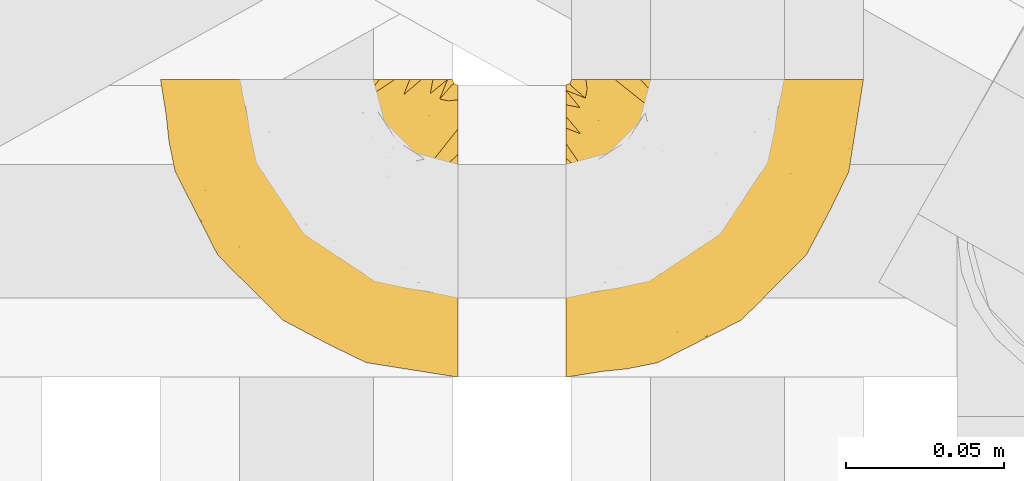
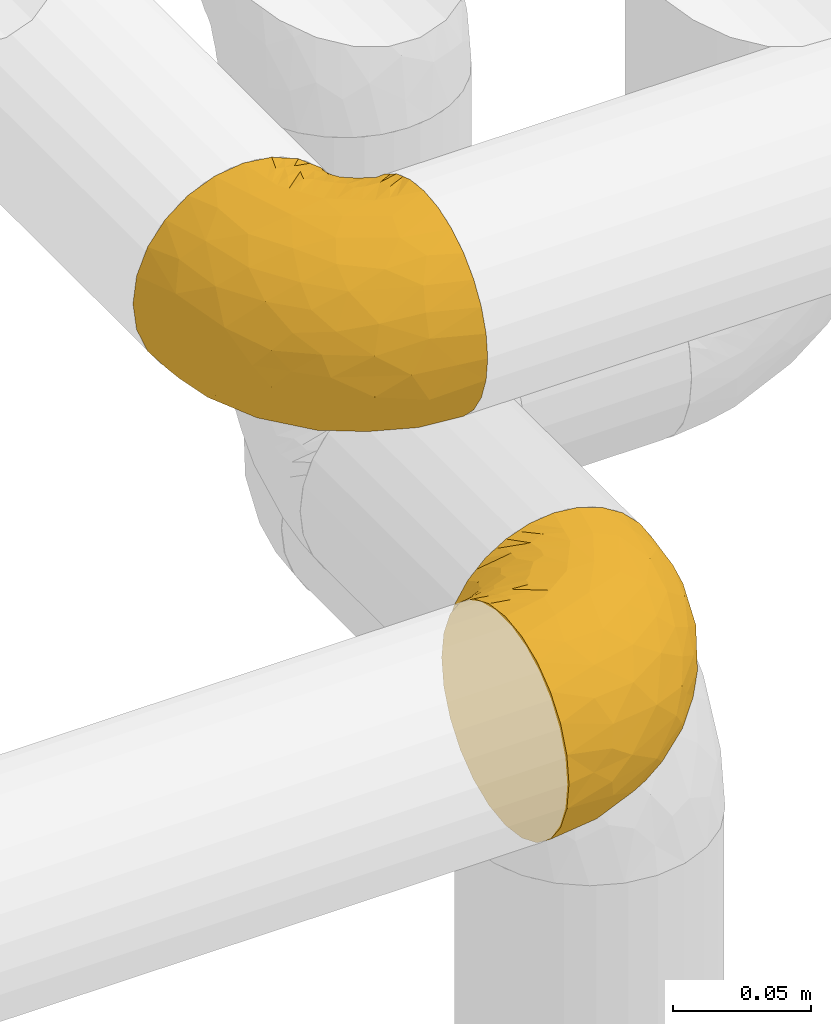
# One storey, part 173 of 827: 2 coverings.
"""IFC2X3 building model written with IfcOpenShell, lengths in millimetres."""

from ifc_helpers import new_model, entity, si_unit, converted_unit, derived_unit, direction, frame, origin, place, context, subcontext, project, spatial, faceted_brep, element, save


model = new_model("IFC2X3")

# Units and contexts
model_context = context("Model", 3, precision=0.01, world=origin(), true_north=direction((6.12303176911189e-17, 1.0)))
body_context = subcontext(model_context, "Body", "Model", "MODEL_VIEW")
ifc_project = project(units=[si_unit("LENGTHUNIT", "METRE", prefix="MILLI"), si_unit("AREAUNIT", "SQUARE_METRE"), si_unit("VOLUMEUNIT", "CUBIC_METRE"), converted_unit("PLANEANGLEUNIT", "DEGREE", entity("IfcRatioMeasure", 0.0174532925199433), si_unit("PLANEANGLEUNIT", "RADIAN"), dimensions=[0, 0, 0, 0, 0, 0, 0]), si_unit("MASSUNIT", "GRAM", prefix="KILO"), derived_unit("MASSDENSITYUNIT", [(si_unit("MASSUNIT", "GRAM", prefix="KILO"), 1), (si_unit("LENGTHUNIT", "METRE"), -3)]), derived_unit("MOMENTOFINERTIAUNIT", [(si_unit("LENGTHUNIT", "METRE"), 4)]), si_unit("TIMEUNIT", "SECOND"), si_unit("FREQUENCYUNIT", "HERTZ"), si_unit("THERMODYNAMICTEMPERATUREUNIT", "DEGREE_CELSIUS"), derived_unit("THERMALTRANSMITTANCEUNIT", [(si_unit("MASSUNIT", "GRAM", prefix="KILO"), 1), (si_unit("THERMODYNAMICTEMPERATUREUNIT", "KELVIN"), -1), (si_unit("TIMEUNIT", "SECOND"), -3)]), derived_unit("VOLUMETRICFLOWRATEUNIT", [(si_unit("LENGTHUNIT", "METRE"), 3), (si_unit("TIMEUNIT", "SECOND"), -1)]), derived_unit("MASSFLOWRATEUNIT", [(si_unit("MASSUNIT", "GRAM", prefix="KILO"), 1), (si_unit("TIMEUNIT", "SECOND"), -1)]), derived_unit("ROTATIONALFREQUENCYUNIT", [(si_unit("TIMEUNIT", "SECOND"), -1)]), si_unit("ELECTRICCURRENTUNIT", "AMPERE"), si_unit("ELECTRICVOLTAGEUNIT", "VOLT"), si_unit("POWERUNIT", "WATT"), si_unit("FORCEUNIT", "NEWTON", prefix="KILO"), si_unit("ILLUMINANCEUNIT", "LUX"), si_unit("LUMINOUSFLUXUNIT", "LUMEN"), si_unit("LUMINOUSINTENSITYUNIT", "CANDELA"), derived_unit("USERDEFINED", [(si_unit("MASSUNIT", "GRAM", prefix="KILO"), -1), (si_unit("LENGTHUNIT", "METRE"), -2), (si_unit("TIMEUNIT", "SECOND"), 3), (si_unit("LUMINOUSFLUXUNIT", "LUMEN"), 1)]), derived_unit("LINEARVELOCITYUNIT", [(si_unit("LENGTHUNIT", "METRE"), 1), (si_unit("TIMEUNIT", "SECOND"), -1)]), si_unit("PRESSUREUNIT", "PASCAL"), derived_unit("USERDEFINED", [(si_unit("LENGTHUNIT", "METRE"), -2), (si_unit("MASSUNIT", "GRAM", prefix="KILO"), 1), (si_unit("TIMEUNIT", "SECOND"), -2)]), derived_unit("LINEARFORCEUNIT", [(si_unit("MASSUNIT", "GRAM", prefix="KILO"), 1), (si_unit("LENGTHUNIT", "METRE"), 1), (si_unit("TIMEUNIT", "SECOND"), -2), (si_unit("LENGTHUNIT", "METRE"), -1)]), derived_unit("PLANARFORCEUNIT", [(si_unit("MASSUNIT", "GRAM", prefix="KILO"), 1), (si_unit("LENGTHUNIT", "METRE"), 1), (si_unit("TIMEUNIT", "SECOND"), -2), (si_unit("LENGTHUNIT", "METRE"), -2)])], contexts=[model_context])

# Site, building, storey
site_placement = place(None, origin())
site = spatial("IfcSite", under=ifc_project, at=site_placement, CompositionType="ELEMENT")
building_placement = place(site_placement, origin())
building = spatial("IfcBuilding", under=site, at=building_placement, CompositionType="ELEMENT")
storey_placement = place(building_placement, frame((0.0, 0.0, 28200.0)))
storey = spatial("IfcBuildingStorey", under=building, at=storey_placement, Name="08", CompositionType="ELEMENT", Elevation=28200.0)

# Coverings
covering_1_placement = place(storey_placement, frame((35550.49, 12708.38, 2751.81)))
element("IfcCovering", 1, at=covering_1_placement, inside=storey, Name=":ADSK_", ObjectType=":ADSK_", PredefinedType="INSULATION", context=body_context, shape_type="Brep", body=[
    faceted_brep([(59.89, 95.8, 92.84), (69.65, 95.8, 89.42), (78.41, 95.8, 83.91), (85.73, 95.8, 76.59), (91.23, 95.8, 67.83), (94.64, 95.8, 58.07), (95.8, 95.8, 47.8), (94.64, 95.8, 37.51), (91.22, 95.8, 27.74), (85.72, 95.8, 18.98), (78.4, 95.8, 11.67), (69.64, 95.8, 6.17), (59.88, 95.8, 2.75), (49.6, 95.8, 1.6), (45.46, 95.8, 2.06), (42.39, 95.8, 2.41), (39.32, 95.8, 2.75), (34.43, 95.8, 4.46), (29.55, 95.8, 6.17), (25.17, 95.8, 8.93), (20.79, 95.8, 11.68), (17.13, 95.8, 15.34), (13.48, 95.8, 19.0), (7.97, 95.8, 27.76), (6.27, 95.8, 32.64), (4.56, 95.8, 37.52), (3.4, 95.8, 47.8), (4.56, 95.8, 58.08), (6.27, 95.8, 62.96), (7.98, 95.8, 67.85), (13.49, 95.8, 76.61), (17.14, 95.8, 80.26), (20.8, 95.8, 83.92), (25.18, 95.8, 86.67), (29.56, 95.8, 89.42), (34.44, 95.8, 91.13), (39.33, 95.8, 92.84), (42.39, 95.8, 93.18), (45.46, 95.8, 93.53), (49.6, 95.8, 94.0), (1.6, 94.0, 47.8), (1.6, 92.42, 35.84), (1.6, 87.81, 24.7), (1.6, 84.13, 19.91), (1.6, 80.46, 15.13), (1.6, 75.68, 11.46), (1.6, 70.9, 7.78), (1.6, 65.32, 5.48), (1.6, 59.75, 3.17), (1.6, 56.14, 2.69), (1.6, 54.05, 2.42), (1.6, 51.97, 2.14), (1.6, 47.8, 1.6), (1.6, 35.84, 3.17), (1.6, 24.7, 7.78), (1.6, 15.13, 15.13), (1.6, 7.78, 24.7), (1.6, 3.17, 35.84), (1.6, 1.6, 47.8), (1.6, 3.17, 59.75), (1.6, 7.78, 70.9), (1.6, 15.13, 80.46), (1.6, 24.7, 87.81), (1.6, 35.84, 92.42), (1.6, 47.8, 94.0), (1.6, 51.97, 93.45), (1.6, 56.14, 92.9), (1.6, 59.75, 92.42), (1.6, 65.32, 90.11), (1.6, 70.9, 87.81), (1.6, 75.68, 84.13), (1.6, 80.46, 80.46), (1.6, 84.13, 75.68), (1.6, 87.81, 70.9), (1.6, 92.42, 59.75), (36.81, 15.84, 71.98), (23.28, 6.99, 63.6), (45.8, 14.39, 59.72), (30.71, 6.2, 47.8), (21.2, 4.26, 55.16), (12.96, 3.39, 47.8), (66.2, 31.2, 63.76), (54.52, 26.47, 72.22), (17.98, 11.44, 74.18), (36.69, 47.65, 92.52), (35.54, 61.85, 94.0), (31.65, 59.25, 94.0), (27.75, 56.65, 94.0), (23.86, 54.05, 94.0), (19.97, 51.45, 94.0), (22.8, 19.8, 82.14), (42.68, 26.22, 80.34), (33.22, 31.57, 87.52), (59.45, 38.36, 79.59), (71.51, 51.54, 78.25), (62.67, 51.6, 85.01), (54.51, 55.97, 90.25), (47.57, 62.88, 93.2), (48.82, 41.35, 87.23), (74.99, 82.24, 85.55), (18.71, 40.88, 93.0), (15.75, 29.0, 89.31), (91.18, 74.06, 61.31), (85.28, 54.53, 56.86), (82.59, 57.97, 68.34), (75.79, 43.81, 65.71), (74.99, 38.22, 56.99), (67.27, 38.33, 72.15), (87.38, 74.76, 70.34), (82.04, 76.84, 78.36), (94.0, 84.43, 47.8), (77.81, 40.42, 47.8), (67.39, 30.0, 47.8), (56.21, 78.67, 93.06), (48.86, 92.06, 94.0), (48.12, 88.32, 94.0), (47.57, 85.6, 94.0), (47.03, 82.88, 94.0), (46.49, 80.15, 94.0), (45.95, 77.43, 94.0), (65.79, 76.36, 89.88), (17.24, 50.91, 94.0), (14.52, 50.36, 94.0), (11.79, 49.82, 94.0), (9.07, 49.28, 94.0), (7.2, 48.91, 94.0), (5.33, 48.54, 94.0), (91.19, 66.68, 47.8), (43.35, 73.53, 94.0), (40.74, 69.64, 94.0), (38.14, 65.75, 94.0), (72.73, 66.13, 83.7), (56.97, 19.58, 47.8), (62.23, 24.64, 55.9), (84.5, 53.55, 47.8), (43.84, 12.89, 47.8), (12.05, 82.81, 81.75), (18.95, 81.22, 86.43), (13.02, 86.57, 79.8), (8.35, 92.75, 69.84), (11.09, 72.26, 88.08), (13.66, 64.73, 91.6), (20.08, 62.45, 92.93), (9.62, 60.63, 92.43), (9.49, 56.91, 93.24), (16.1, 58.14, 93.36), (3.43, 93.7, 57.25), (26.63, 83.4, 89.41), (33.73, 75.54, 92.89), (34.77, 79.46, 92.66), (6.76, 82.28, 79.58), (13.32, 76.25, 86.51), (19.95, 90.18, 83.91), (27.06, 87.92, 88.76), (8.67, 65.12, 90.94), (26.11, 71.71, 91.94), (29.3, 75.21, 91.98), (6.33, 78.6, 82.79), (39.93, 87.27, 93.16), (6.05, 86.94, 73.94), (34.41, 86.1, 91.89), (2.87, 94.52, 47.8), (14.64, 89.68, 79.5), (20.93, 66.23, 92.22), (21.12, 84.69, 86.29), (27.43, 91.08, 88.56), (7.54, 71.77, 87.72), (18.46, 76.21, 88.33), (23.88, 68.58, 92.18), (7.78, 89.94, 71.78), (13.31, 76.25, 9.09), (11.09, 72.26, 7.51), (6.33, 78.6, 12.8), (9.07, 49.28, 1.6), (5.33, 48.54, 1.6), (14.52, 50.36, 1.6), (11.79, 49.82, 1.6), (3.43, 93.7, 38.35), (7.77, 89.95, 23.83), (47.03, 82.88, 1.6), (47.57, 85.6, 1.6), (48.86, 92.06, 1.6), (48.12, 88.32, 1.6), (14.62, 89.68, 16.1), (27.03, 87.92, 6.84), (20.08, 62.45, 2.66), (20.92, 66.23, 3.37), (27.75, 56.65, 1.6), (31.65, 59.25, 1.6), (9.62, 60.63, 3.16), (9.49, 56.91, 2.35), (8.34, 92.76, 25.77), (6.75, 82.28, 16.02), (12.05, 82.81, 13.85), (23.86, 54.05, 1.6), (19.97, 51.45, 1.6), (16.1, 58.14, 2.23), (19.94, 90.18, 11.69), (21.1, 84.7, 9.31), (39.93, 87.25, 2.43), (33.68, 75.58, 2.71), (29.29, 75.2, 3.61), (26.62, 83.39, 6.18), (26.09, 71.7, 3.66), (18.94, 81.22, 9.17), (27.88, 90.73, 6.77), (34.76, 79.47, 2.93), (6.05, 86.94, 21.66), (38.14, 65.75, 1.6), (12.8, 86.75, 16.09), (34.42, 86.08, 3.7), (45.95, 77.43, 1.6), (43.35, 73.53, 1.6), (40.74, 69.64, 1.6), (13.66, 64.73, 3.99), (17.24, 50.91, 1.6), (8.67, 65.12, 4.65), (35.54, 61.85, 1.6), (23.84, 68.61, 3.43), (18.44, 76.22, 7.27), (6.03, 74.03, 9.46), (46.49, 80.15, 1.6), (34.53, 49.81, 2.4), (21.2, 4.26, 40.43), (23.82, 19.95, 13.57), (41.32, 30.61, 11.3), (47.63, 25.71, 18.65), (52.66, 22.43, 27.26), (36.82, 15.84, 23.61), (49.75, 60.69, 3.07), (19.08, 40.49, 2.69), (45.8, 14.39, 35.87), (23.28, 6.99, 31.99), (21.36, 29.56, 6.71), (17.98, 11.44, 21.41), (82.58, 57.98, 27.24), (91.18, 74.06, 34.26), (85.28, 54.52, 38.73), (73.89, 43.47, 26.97), (66.2, 31.2, 31.83), (62.43, 33.27, 23.4), (63.54, 64.26, 6.91), (58.46, 74.29, 3.4), (67.17, 80.41, 5.84), (62.23, 24.64, 39.69), (81.55, 73.62, 17.6), (74.8, 78.98, 10.38), (75.84, 53.69, 20.6), (41.45, 42.86, 5.36), (76.73, 41.67, 35.73), (88.21, 79.66, 24.84), (71.61, 58.41, 13.87), (56.24, 47.11, 9.06), (59.45, 38.36, 15.99)], [[[0, 1, 2, 3, 4, 5, 6, 7, 8, 9, 10, 11, 12, 13, 14, 15, 16, 17, 18, 19, 20, 21, 22, 23, 24, 25, 26, 27, 28, 29, 30, 31, 32, 33, 34, 35, 36, 37, 38, 39]], [[40, 41, 42, 43, 44, 45, 46, 47, 48, 49, 50, 51, 52, 53, 54, 55, 56, 57, 58, 59, 60, 61, 62, 63, 64, 65, 66, 67, 68, 69, 70, 71, 72, 73, 74]], [[75, 76, 77]], [[78, 79, 80]], [[77, 81, 82]], [[76, 75, 83]], [[84, 85, 86, 87, 88, 89]], [[90, 91, 92]], [[76, 60, 59]], [[93, 94, 95]], [[90, 62, 61]], [[83, 61, 60]], [[96, 97, 84]], [[98, 93, 95]], [[2, 1, 99]], [[100, 84, 89]], [[62, 101, 63]], [[4, 102, 5]], [[92, 84, 100]], [[103, 102, 104]], [[103, 105, 106]], [[93, 107, 94]], [[3, 108, 4]], [[92, 101, 90]], [[108, 3, 109]], [[102, 110, 5]], [[93, 82, 107]], [[102, 108, 104]], [[111, 106, 112]], [[109, 2, 99]], [[113, 39, 114, 115, 116, 117, 118, 119]], [[120, 0, 113]], [[100, 89, 121, 122, 123, 124, 125, 126, 64]], [[127, 102, 103]], [[97, 119, 128, 129, 130, 85]], [[99, 120, 131]], [[132, 133, 77]], [[59, 80, 79]], [[3, 2, 109]], [[98, 84, 92]], [[94, 109, 131]], [[120, 1, 0]], [[93, 91, 82]], [[104, 94, 105]], [[97, 113, 119]], [[95, 120, 96]], [[83, 90, 61]], [[91, 93, 98]], [[64, 63, 100]], [[100, 63, 101]], [[77, 76, 79]], [[133, 106, 81]], [[84, 97, 85]], [[113, 96, 120]], [[113, 97, 96]], [[39, 113, 0]], [[110, 102, 127]], [[110, 6, 5]], [[103, 111, 134, 127]], [[90, 75, 91]], [[82, 81, 107]], [[91, 75, 82]], [[77, 82, 75]], [[76, 83, 60]], [[90, 83, 75]], [[105, 107, 81]], [[94, 131, 95]], [[105, 94, 107]], [[109, 94, 104]], [[120, 95, 131]], [[98, 95, 96]], [[84, 98, 96]], [[98, 92, 91]], [[106, 105, 81]], [[103, 104, 105]], [[112, 106, 133]], [[103, 106, 111]], [[112, 133, 132]], [[81, 77, 133]], [[77, 78, 135, 132]], [[120, 99, 1]], [[109, 99, 131]], [[59, 58, 80]], [[59, 79, 76]], [[90, 101, 62]], [[100, 101, 92]], [[4, 108, 102]], [[109, 104, 108]], [[78, 77, 79]], [[136, 137, 138]], [[29, 28, 27, 139]], [[140, 141, 142]], [[143, 144, 121]], [[145, 89, 88]], [[146, 139, 27]], [[147, 148, 149]], [[136, 150, 151]], [[146, 40, 74]], [[26, 146, 27]], [[152, 147, 153]], [[35, 116, 36]], [[73, 72, 150]], [[114, 39, 38, 37, 36, 116, 115]], [[145, 154, 143]], [[155, 85, 130]], [[156, 148, 147]], [[150, 157, 151]], [[117, 35, 158]], [[31, 152, 153]], [[159, 74, 73]], [[160, 128, 119]], [[66, 65, 64, 126, 125, 124, 123, 122, 67]], [[161, 146, 26]], [[29, 162, 30]], [[148, 129, 149]], [[68, 143, 69]], [[129, 128, 149]], [[163, 87, 86]], [[130, 129, 148]], [[122, 144, 67]], [[152, 164, 147]], [[160, 119, 158]], [[165, 32, 153]], [[149, 153, 147]], [[128, 160, 149]], [[32, 165, 33]], [[144, 143, 68]], [[89, 145, 143]], [[87, 163, 142]], [[166, 154, 141]], [[88, 87, 142]], [[160, 153, 149]], [[153, 32, 31]], [[31, 30, 152]], [[30, 162, 152]], [[164, 152, 162]], [[162, 137, 164]], [[156, 147, 164]], [[155, 130, 156]], [[164, 137, 156]], [[156, 137, 155]], [[167, 137, 136]], [[168, 85, 155]], [[151, 168, 167]], [[167, 168, 155]], [[163, 151, 140]], [[71, 157, 72]], [[151, 167, 136]], [[88, 141, 145]], [[143, 154, 69]], [[145, 141, 154]], [[70, 166, 71]], [[141, 140, 166]], [[70, 69, 154]], [[140, 157, 71]], [[159, 73, 150]], [[138, 137, 162]], [[159, 136, 169]], [[136, 159, 150]], [[74, 159, 169]], [[151, 157, 140]], [[150, 72, 157]], [[168, 151, 163]], [[137, 167, 155]], [[163, 86, 168]], [[85, 168, 86]], [[116, 35, 117]], [[130, 148, 156]], [[67, 144, 68]], [[121, 89, 143]], [[144, 122, 121]], [[40, 146, 161]], [[169, 146, 74]], [[158, 35, 34]], [[160, 158, 34]], [[158, 119, 118, 117]], [[139, 146, 169]], [[138, 139, 169]], [[162, 29, 139]], [[160, 34, 33]], [[140, 142, 163]], [[88, 142, 141]], [[71, 166, 140]], [[154, 166, 70]], [[139, 138, 162]], [[169, 136, 138]], [[153, 160, 165]], [[160, 33, 165]], [[170, 171, 172]], [[173, 174, 52, 51, 50, 49, 48, 175, 176]], [[177, 178, 41]], [[179, 17, 180]], [[14, 13, 181, 182, 180, 16, 15]], [[183, 23, 22]], [[21, 20, 184]], [[185, 186, 187]], [[186, 188, 187]], [[43, 172, 44]], [[189, 190, 47]], [[25, 24, 23, 191]], [[170, 192, 193]], [[40, 161, 177]], [[194, 195, 196]], [[26, 25, 177]], [[197, 198, 183]], [[199, 17, 179]], [[47, 46, 189]], [[200, 201, 202]], [[201, 203, 204]], [[205, 206, 184]], [[207, 41, 178]], [[18, 17, 199]], [[16, 180, 17]], [[202, 201, 198]], [[208, 201, 200]], [[161, 26, 177]], [[48, 47, 190]], [[196, 195, 189]], [[197, 184, 202]], [[204, 193, 209]], [[210, 211, 212]], [[206, 212, 213]], [[205, 19, 210]], [[184, 206, 202]], [[210, 212, 206]], [[185, 194, 214]], [[189, 215, 190]], [[216, 45, 214]], [[186, 171, 170]], [[189, 216, 196]], [[21, 184, 197]], [[194, 185, 187]], [[21, 197, 22]], [[198, 197, 202]], [[183, 22, 197]], [[206, 200, 202]], [[204, 183, 198]], [[201, 208, 203]], [[203, 208, 217]], [[204, 198, 201]], [[217, 188, 218]], [[193, 219, 170]], [[171, 186, 185]], [[170, 218, 186]], [[170, 219, 218]], [[42, 207, 192]], [[171, 220, 172]], [[216, 189, 46]], [[214, 194, 196]], [[44, 220, 45]], [[214, 196, 216]], [[216, 46, 45]], [[214, 45, 220]], [[192, 43, 42]], [[204, 203, 219]], [[207, 193, 192]], [[209, 193, 178]], [[41, 207, 42]], [[193, 207, 178]], [[43, 192, 172]], [[170, 172, 192]], [[204, 219, 193]], [[219, 203, 218]], [[217, 218, 203]], [[188, 186, 218]], [[206, 213, 200]], [[208, 200, 213]], [[199, 210, 18]], [[215, 189, 195]], [[215, 175, 190]], [[175, 48, 190]], [[199, 179, 221, 211]], [[210, 199, 211]], [[25, 191, 177]], [[40, 177, 41]], [[178, 177, 191]], [[23, 183, 191]], [[209, 191, 183]], [[205, 20, 19]], [[19, 18, 210]], [[171, 185, 214]], [[172, 220, 44]], [[214, 220, 171]], [[191, 209, 178]], [[204, 209, 183]], [[206, 205, 210]], [[20, 205, 184]], [[222, 195, 194, 187, 188, 217]], [[57, 223, 80]], [[224, 225, 226]], [[226, 227, 228]], [[229, 217, 208, 213, 212, 211]], [[230, 52, 174, 173, 176, 175, 215, 195]], [[231, 232, 228]], [[231, 78, 223]], [[223, 57, 232]], [[224, 233, 225]], [[233, 54, 53]], [[234, 232, 56]], [[56, 55, 234]], [[234, 224, 228]], [[235, 236, 237]], [[224, 55, 54]], [[238, 239, 240]], [[52, 230, 53]], [[241, 242, 243]], [[227, 244, 231]], [[13, 12, 242]], [[236, 8, 7]], [[9, 245, 10]], [[10, 246, 11]], [[238, 247, 235]], [[222, 229, 248]], [[242, 211, 221, 179, 180, 182, 181, 13]], [[233, 53, 230]], [[111, 112, 249]], [[250, 8, 236]], [[246, 251, 241]], [[8, 250, 9]], [[127, 236, 110]], [[248, 229, 252]], [[246, 10, 245]], [[235, 245, 250]], [[236, 7, 110]], [[235, 249, 238]], [[237, 236, 127]], [[243, 11, 246]], [[252, 229, 241]], [[56, 232, 57]], [[222, 230, 195]], [[225, 248, 252]], [[248, 233, 230]], [[54, 233, 224]], [[231, 228, 227]], [[244, 132, 231]], [[248, 225, 233]], [[226, 225, 253]], [[235, 250, 236]], [[245, 9, 250]], [[251, 246, 245]], [[243, 246, 241]], [[247, 245, 235]], [[252, 251, 253]], [[229, 222, 217]], [[230, 222, 248]], [[7, 6, 110]], [[237, 127, 134, 111]], [[238, 249, 239]], [[224, 234, 55]], [[232, 234, 228]], [[242, 241, 229]], [[12, 11, 243]], [[211, 242, 229]], [[12, 243, 242]], [[80, 223, 78]], [[80, 58, 57]], [[231, 223, 232]], [[227, 240, 239]], [[224, 226, 228]], [[240, 226, 253]], [[227, 239, 244]], [[226, 240, 227]], [[251, 247, 253]], [[240, 253, 247]], [[249, 235, 237]], [[237, 111, 249]], [[112, 132, 244]], [[112, 244, 249]], [[78, 231, 132, 135]], [[249, 244, 239]], [[247, 238, 240]], [[245, 247, 251]], [[251, 252, 241]], [[225, 252, 253]]]),
])
covering_2_placement = place(storey_placement, frame((35422.24, 12708.37, 2952.2)))
element("IfcCovering", 2, at=covering_2_placement, inside=storey, Name=":ADSK_", ObjectType=":ADSK_", PredefinedType="INSULATION", context=body_context, shape_type="Brep", body=[
    faceted_brep([(95.8, 18.98, 83.91), (95.8, 11.67, 76.59), (95.8, 6.17, 67.83), (95.8, 2.75, 58.07), (95.8, 1.6, 47.8), (95.8, 2.75, 37.51), (95.8, 6.17, 27.74), (95.8, 11.68, 18.98), (95.8, 19.0, 11.67), (95.8, 27.76, 6.17), (95.8, 37.52, 2.75), (95.8, 47.8, 1.6), (95.8, 51.94, 2.06), (95.8, 55.01, 2.41), (95.8, 58.08, 2.75), (95.8, 62.96, 4.46), (95.8, 67.85, 6.17), (95.8, 72.23, 8.93), (95.8, 76.61, 11.68), (95.8, 80.26, 15.34), (95.8, 83.92, 19.0), (95.8, 89.42, 27.76), (95.8, 91.13, 32.64), (95.8, 92.84, 37.52), (95.8, 94.0, 47.8), (95.8, 92.84, 58.08), (95.8, 91.13, 62.96), (95.8, 89.42, 67.85), (95.8, 83.91, 76.61), (95.8, 80.25, 80.26), (95.8, 76.59, 83.92), (95.8, 72.21, 86.67), (95.8, 67.83, 89.42), (95.8, 62.95, 91.13), (95.8, 58.07, 92.84), (95.8, 55.0, 93.18), (95.8, 51.94, 93.53), (95.8, 47.8, 94.0), (95.8, 37.51, 92.84), (95.8, 27.74, 89.42), (94.0, 95.8, 47.8), (92.42, 95.8, 35.84), (87.81, 95.8, 24.7), (84.13, 95.8, 19.91), (80.46, 95.8, 15.13), (75.68, 95.8, 11.46), (70.9, 95.8, 7.78), (65.32, 95.8, 5.48), (59.75, 95.8, 3.17), (56.14, 95.8, 2.69), (54.06, 95.8, 2.42), (51.97, 95.8, 2.14), (47.8, 95.8, 1.6), (35.84, 95.8, 3.17), (24.7, 95.8, 7.78), (15.13, 95.8, 15.13), (7.78, 95.8, 24.7), (3.17, 95.8, 35.84), (1.6, 95.8, 47.8), (3.17, 95.8, 59.75), (7.78, 95.8, 70.9), (15.13, 95.8, 80.46), (24.7, 95.8, 87.81), (35.84, 95.8, 92.42), (47.8, 95.8, 94.0), (51.97, 95.8, 93.45), (56.14, 95.8, 92.9), (59.75, 95.8, 92.42), (65.32, 95.8, 90.11), (70.9, 95.8, 87.81), (75.68, 95.8, 84.13), (80.46, 95.8, 80.46), (84.13, 95.8, 75.68), (87.81, 95.8, 70.9), (92.42, 95.8, 59.75), (15.84, 60.58, 71.98), (6.99, 74.11, 63.6), (14.39, 51.59, 59.72), (6.21, 66.69, 47.8), (4.26, 76.19, 55.16), (3.39, 84.43, 47.8), (31.2, 31.2, 63.76), (26.47, 42.88, 72.22), (11.44, 79.41, 74.18), (47.66, 60.7, 92.52), (61.85, 61.85, 94.0), (59.25, 65.75, 94.0), (56.65, 69.64, 94.0), (54.05, 73.53, 94.0), (51.45, 77.43, 94.0), (19.8, 74.59, 82.14), (26.22, 54.72, 80.34), (31.58, 64.18, 87.52), (38.36, 37.94, 79.59), (51.54, 25.89, 78.25), (51.6, 34.73, 85.01), (55.97, 42.89, 90.25), (62.88, 49.83, 93.2), (41.35, 48.58, 87.23), (82.24, 22.41, 85.55), (40.88, 78.69, 93.0), (29.0, 81.64, 89.31), (74.06, 6.22, 61.31), (54.53, 12.11, 56.86), (57.98, 14.81, 68.34), (43.81, 21.61, 65.71), (38.22, 22.41, 56.99), (38.33, 30.12, 72.15), (74.76, 10.01, 70.34), (76.85, 15.36, 78.36), (84.43, 3.39, 47.8), (40.43, 19.59, 47.8), (30.01, 30.01, 47.8), (78.67, 41.19, 93.06), (92.06, 48.54, 94.0), (88.32, 49.28, 94.0), (85.6, 49.82, 94.0), (82.88, 50.37, 94.0), (80.15, 50.91, 94.0), (77.43, 51.45, 94.0), (76.36, 31.61, 89.88), (50.91, 80.15, 94.0), (50.37, 82.88, 94.0), (49.82, 85.6, 94.0), (49.28, 88.32, 94.0), (48.91, 90.19, 94.0), (48.54, 92.06, 94.0), (66.69, 6.21, 47.8), (73.53, 54.05, 94.0), (69.64, 56.65, 94.0), (65.75, 59.25, 94.0), (66.13, 24.66, 83.7), (19.59, 40.43, 47.8), (24.64, 35.17, 55.9), (53.56, 12.9, 47.8), (12.9, 53.56, 47.8), (82.81, 85.34, 81.75), (81.22, 78.44, 86.43), (86.57, 84.37, 79.8), (92.75, 89.05, 69.84), (89.68, 82.76, 79.5), (72.26, 86.31, 88.08), (64.73, 83.73, 91.6), (62.45, 77.31, 92.93), (60.63, 87.78, 92.43), (56.91, 87.91, 93.24), (58.14, 81.29, 93.36), (93.7, 93.97, 57.25), (83.4, 70.76, 89.41), (75.54, 63.67, 92.89), (79.46, 62.62, 92.66), (82.28, 90.64, 79.58), (76.25, 84.08, 86.51), (84.69, 76.28, 86.29), (90.18, 77.45, 83.91), (86.94, 91.35, 73.94), (65.12, 88.72, 90.94), (71.71, 71.28, 91.94), (75.21, 68.09, 91.98), (78.6, 91.07, 82.79), (87.27, 57.47, 93.16), (87.92, 70.34, 88.76), (86.1, 62.99, 91.89), (94.52, 94.52, 47.8), (66.23, 76.47, 92.22), (91.08, 69.96, 88.56), (71.77, 89.86, 87.72), (76.21, 78.94, 88.33), (68.59, 73.51, 92.18), (89.94, 89.62, 71.78), (76.22, 78.96, 7.27), (81.22, 78.46, 9.17), (71.7, 71.31, 3.66), (49.28, 88.32, 1.6), (48.54, 92.06, 1.6), (50.37, 82.88, 1.6), (49.82, 85.6, 1.6), (93.7, 93.97, 38.35), (89.95, 89.63, 23.84), (82.88, 50.37, 1.6), (85.6, 49.82, 1.6), (92.06, 48.54, 1.6), (88.32, 49.28, 1.6), (89.68, 82.77, 16.1), (87.92, 70.36, 6.84), (62.45, 77.31, 2.66), (66.24, 76.47, 3.37), (56.65, 69.64, 1.6), (59.25, 65.75, 1.6), (78.6, 91.06, 12.8), (60.63, 87.78, 3.16), (56.91, 87.91, 2.35), (92.76, 89.06, 25.77), (76.25, 84.09, 9.09), (82.28, 90.65, 16.02), (82.81, 85.35, 13.85), (54.05, 73.53, 1.6), (51.45, 77.43, 1.6), (58.14, 81.29, 2.23), (90.18, 77.46, 11.69), (84.7, 76.29, 9.31), (87.25, 57.47, 2.43), (75.58, 63.71, 2.71), (75.2, 68.11, 3.61), (83.39, 70.77, 6.18), (90.73, 69.52, 6.77), (79.47, 62.64, 2.93), (86.94, 91.35, 21.66), (65.75, 59.25, 1.6), (86.75, 84.6, 16.09), (86.08, 62.98, 3.7), (77.43, 51.45, 1.6), (73.53, 54.05, 1.6), (69.64, 56.65, 1.6), (64.73, 83.73, 3.99), (50.91, 80.15, 1.6), (65.12, 88.72, 4.65), (72.26, 86.3, 7.51), (61.85, 61.85, 1.6), (68.62, 73.56, 3.43), (74.03, 91.36, 9.46), (80.15, 50.91, 1.6), (49.81, 62.87, 2.4), (4.26, 76.19, 40.43), (19.95, 73.57, 13.57), (30.61, 56.07, 11.3), (25.71, 49.77, 18.65), (22.43, 44.73, 27.26), (15.85, 60.58, 23.61), (60.69, 47.64, 3.07), (40.49, 78.32, 2.69), (14.39, 51.59, 35.87), (6.99, 74.11, 31.99), (29.56, 76.04, 6.71), (11.45, 79.41, 21.41), (57.98, 14.82, 27.24), (74.06, 6.22, 34.26), (54.52, 12.12, 38.73), (43.47, 23.51, 26.97), (31.2, 31.2, 31.83), (33.27, 34.96, 23.4), (64.26, 33.86, 6.91), (74.29, 38.94, 3.4), (80.41, 30.23, 5.84), (41.67, 20.67, 35.73), (24.64, 35.17, 39.69), (73.62, 15.85, 17.6), (78.98, 22.59, 10.38), (53.69, 21.56, 20.6), (42.86, 55.94, 5.36), (79.66, 9.19, 24.84), (58.41, 25.79, 13.87), (47.11, 41.16, 9.06), (38.37, 37.95, 15.99)], [[[0, 1, 2, 3, 4, 5, 6, 7, 8, 9, 10, 11, 12, 13, 14, 15, 16, 17, 18, 19, 20, 21, 22, 23, 24, 25, 26, 27, 28, 29, 30, 31, 32, 33, 34, 35, 36, 37, 38, 39]], [[40, 41, 42, 43, 44, 45, 46, 47, 48, 49, 50, 51, 52, 53, 54, 55, 56, 57, 58, 59, 60, 61, 62, 63, 64, 65, 66, 67, 68, 69, 70, 71, 72, 73, 74]], [[75, 76, 77]], [[78, 79, 80]], [[77, 81, 82]], [[76, 75, 83]], [[84, 85, 86, 87, 88, 89]], [[90, 91, 92]], [[76, 60, 59]], [[93, 94, 95]], [[90, 62, 61]], [[83, 61, 60]], [[96, 97, 84]], [[98, 93, 95]], [[0, 39, 99]], [[100, 84, 89]], [[62, 101, 63]], [[2, 102, 3]], [[92, 84, 100]], [[103, 102, 104]], [[103, 105, 106]], [[93, 107, 94]], [[1, 108, 2]], [[92, 101, 90]], [[108, 1, 109]], [[102, 110, 3]], [[93, 82, 107]], [[102, 108, 104]], [[111, 106, 112]], [[109, 0, 99]], [[113, 37, 114, 115, 116, 117, 118, 119]], [[120, 38, 113]], [[100, 89, 121, 122, 123, 124, 125, 126, 64]], [[127, 102, 103]], [[97, 119, 128, 129, 130, 85]], [[99, 120, 131]], [[132, 133, 77]], [[59, 80, 79]], [[1, 0, 109]], [[98, 84, 92]], [[94, 109, 131]], [[120, 39, 38]], [[93, 91, 82]], [[104, 94, 105]], [[97, 113, 119]], [[95, 120, 96]], [[83, 90, 61]], [[91, 93, 98]], [[64, 63, 100]], [[100, 63, 101]], [[77, 76, 79]], [[133, 106, 81]], [[84, 97, 85]], [[113, 96, 120]], [[113, 97, 96]], [[37, 113, 38]], [[110, 102, 127]], [[110, 4, 3]], [[103, 111, 134, 127]], [[90, 75, 91]], [[82, 81, 107]], [[91, 75, 82]], [[77, 82, 75]], [[76, 83, 60]], [[90, 83, 75]], [[105, 107, 81]], [[94, 131, 95]], [[105, 94, 107]], [[109, 94, 104]], [[120, 95, 131]], [[98, 95, 96]], [[84, 98, 96]], [[98, 92, 91]], [[106, 105, 81]], [[103, 104, 105]], [[112, 106, 133]], [[103, 106, 111]], [[112, 133, 132]], [[81, 77, 133]], [[77, 78, 135, 132]], [[120, 99, 39]], [[109, 99, 131]], [[59, 58, 80]], [[59, 79, 76]], [[90, 101, 62]], [[100, 101, 92]], [[2, 108, 102]], [[109, 104, 108]], [[78, 77, 79]], [[136, 137, 138]], [[27, 139, 140]], [[141, 142, 143]], [[144, 145, 121]], [[146, 89, 88]], [[147, 139, 25]], [[148, 149, 150]], [[136, 151, 152]], [[147, 40, 74]], [[24, 147, 25]], [[140, 153, 154]], [[33, 116, 34]], [[155, 73, 151]], [[114, 37, 36, 35, 34, 116, 115]], [[146, 156, 144]], [[157, 85, 130]], [[158, 149, 148]], [[151, 159, 152]], [[117, 33, 160]], [[29, 154, 161]], [[155, 74, 73]], [[162, 128, 119]], [[66, 65, 64, 126, 125, 124, 123, 122, 67]], [[163, 147, 24]], [[27, 140, 28]], [[149, 129, 150]], [[139, 27, 26, 25]], [[68, 144, 69]], [[129, 128, 150]], [[164, 87, 86]], [[130, 129, 149]], [[122, 145, 67]], [[154, 153, 148]], [[162, 119, 160]], [[165, 30, 161]], [[150, 161, 148]], [[128, 162, 150]], [[30, 165, 31]], [[145, 144, 68]], [[89, 146, 144]], [[87, 164, 143]], [[166, 156, 142]], [[88, 87, 143]], [[162, 161, 150]], [[161, 30, 29]], [[154, 29, 28]], [[140, 154, 28]], [[161, 154, 148]], [[140, 137, 153]], [[158, 148, 153]], [[157, 130, 158]], [[153, 137, 158]], [[158, 137, 157]], [[167, 137, 136]], [[168, 85, 157]], [[152, 168, 167]], [[167, 168, 157]], [[164, 152, 141]], [[151, 73, 72]], [[152, 167, 136]], [[88, 142, 146]], [[144, 156, 69]], [[146, 142, 156]], [[70, 166, 71]], [[142, 141, 166]], [[70, 69, 156]], [[141, 159, 71]], [[159, 72, 71]], [[138, 137, 140]], [[155, 136, 169]], [[136, 155, 151]], [[74, 155, 169]], [[152, 159, 141]], [[151, 72, 159]], [[168, 152, 164]], [[137, 167, 157]], [[164, 86, 168]], [[85, 168, 86]], [[116, 33, 117]], [[130, 149, 158]], [[67, 145, 68]], [[121, 89, 144]], [[145, 122, 121]], [[40, 147, 163]], [[169, 147, 74]], [[160, 33, 32]], [[162, 160, 32]], [[160, 119, 118, 117]], [[139, 147, 169]], [[139, 169, 138]], [[162, 32, 31]], [[141, 143, 164]], [[88, 143, 142]], [[71, 166, 141]], [[156, 166, 70]], [[139, 138, 140]], [[169, 136, 138]], [[161, 162, 165]], [[162, 31, 165]], [[170, 171, 172]], [[173, 174, 52, 51, 50, 49, 48, 175, 176]], [[177, 178, 41]], [[179, 15, 180]], [[12, 11, 181, 182, 180, 14, 13]], [[183, 21, 20]], [[19, 18, 184]], [[185, 186, 187]], [[186, 188, 187]], [[43, 189, 44]], [[190, 191, 47]], [[23, 22, 21, 192]], [[193, 194, 195]], [[40, 163, 177]], [[196, 197, 198]], [[24, 23, 177]], [[199, 200, 183]], [[201, 15, 179]], [[47, 46, 190]], [[202, 203, 204]], [[203, 172, 171]], [[205, 206, 184]], [[207, 41, 178]], [[16, 15, 201]], [[14, 180, 15]], [[204, 203, 200]], [[208, 203, 202]], [[163, 24, 177]], [[48, 47, 191]], [[198, 197, 190]], [[199, 184, 204]], [[171, 195, 209]], [[210, 211, 212]], [[206, 212, 213]], [[205, 17, 210]], [[184, 206, 204]], [[210, 212, 206]], [[185, 196, 214]], [[190, 215, 191]], [[216, 45, 214]], [[186, 217, 193]], [[190, 216, 198]], [[199, 20, 19]], [[196, 185, 187]], [[199, 183, 20]], [[184, 199, 19]], [[199, 204, 200]], [[206, 202, 204]], [[171, 183, 200]], [[203, 208, 172]], [[172, 208, 218]], [[171, 200, 203]], [[218, 188, 219]], [[195, 170, 193]], [[217, 186, 185]], [[193, 219, 186]], [[193, 170, 219]], [[207, 194, 42]], [[217, 220, 189]], [[216, 190, 46]], [[214, 196, 198]], [[44, 220, 45]], [[214, 198, 216]], [[216, 46, 45]], [[214, 45, 220]], [[42, 194, 43]], [[189, 193, 217]], [[207, 195, 194]], [[209, 195, 178]], [[41, 207, 42]], [[195, 207, 178]], [[43, 194, 189]], [[193, 189, 194]], [[171, 170, 195]], [[170, 172, 219]], [[218, 219, 172]], [[188, 186, 219]], [[206, 213, 202]], [[208, 202, 213]], [[201, 210, 16]], [[215, 190, 197]], [[215, 175, 191]], [[175, 48, 191]], [[201, 179, 221, 211]], [[210, 201, 211]], [[23, 192, 177]], [[40, 177, 41]], [[183, 209, 192]], [[183, 192, 21]], [[192, 178, 177]], [[205, 18, 17]], [[17, 16, 210]], [[217, 185, 214]], [[189, 220, 44]], [[214, 220, 217]], [[192, 209, 178]], [[171, 209, 183]], [[206, 205, 210]], [[18, 205, 184]], [[222, 197, 196, 187, 188, 218]], [[57, 223, 80]], [[224, 225, 226]], [[226, 227, 228]], [[229, 218, 208, 213, 212, 211]], [[230, 52, 174, 173, 176, 175, 215, 197]], [[231, 232, 228]], [[231, 78, 223]], [[223, 57, 232]], [[224, 233, 225]], [[233, 54, 53]], [[234, 232, 56]], [[56, 55, 234]], [[234, 224, 228]], [[235, 236, 237]], [[224, 55, 54]], [[238, 239, 240]], [[52, 230, 53]], [[241, 242, 243]], [[239, 244, 245]], [[11, 10, 242]], [[236, 6, 5]], [[7, 246, 8]], [[8, 247, 9]], [[238, 248, 235]], [[222, 229, 249]], [[242, 211, 221, 179, 180, 182, 181, 11]], [[233, 53, 230]], [[111, 112, 244]], [[250, 6, 236]], [[247, 251, 241]], [[6, 250, 7]], [[127, 236, 110]], [[249, 229, 252]], [[247, 8, 246]], [[235, 246, 250]], [[236, 5, 110]], [[235, 244, 238]], [[237, 236, 127]], [[243, 9, 247]], [[252, 229, 241]], [[56, 232, 57]], [[222, 230, 197]], [[225, 249, 252]], [[249, 233, 230]], [[54, 233, 224]], [[231, 228, 227]], [[245, 132, 231]], [[249, 225, 233]], [[226, 225, 253]], [[235, 250, 236]], [[246, 7, 250]], [[251, 247, 246]], [[243, 247, 241]], [[248, 246, 235]], [[252, 251, 253]], [[229, 222, 218]], [[230, 222, 249]], [[5, 4, 110]], [[237, 127, 134, 111]], [[238, 244, 239]], [[224, 234, 55]], [[232, 234, 228]], [[242, 241, 229]], [[10, 9, 243]], [[211, 242, 229]], [[10, 243, 242]], [[80, 223, 78]], [[80, 58, 57]], [[231, 223, 232]], [[227, 240, 239]], [[224, 226, 228]], [[240, 226, 253]], [[227, 239, 245]], [[226, 240, 227]], [[251, 248, 253]], [[240, 253, 248]], [[244, 235, 237]], [[237, 111, 244]], [[132, 245, 112]], [[112, 245, 244]], [[135, 78, 231, 132]], [[227, 245, 231]], [[248, 238, 240]], [[246, 248, 251]], [[251, 252, 241]], [[225, 252, 253]]]),
])

save(model, "model.ifc")
